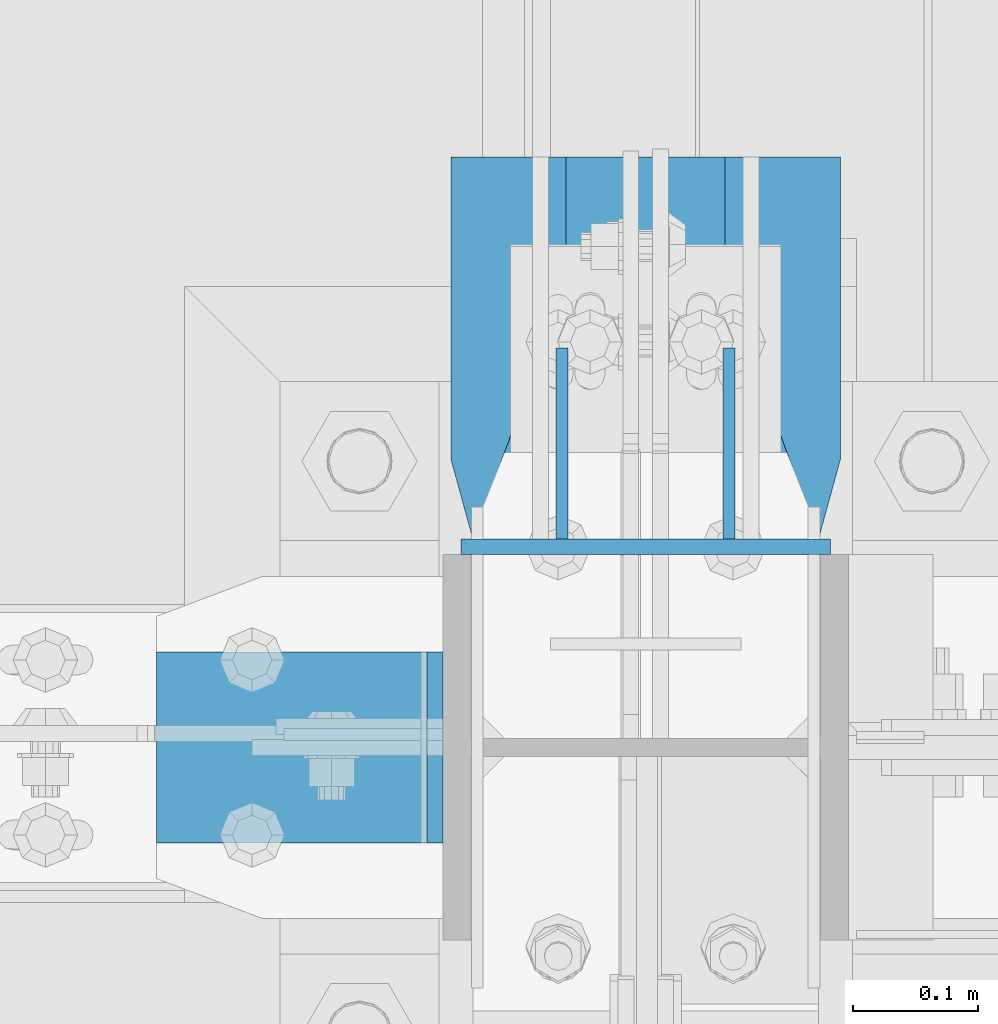
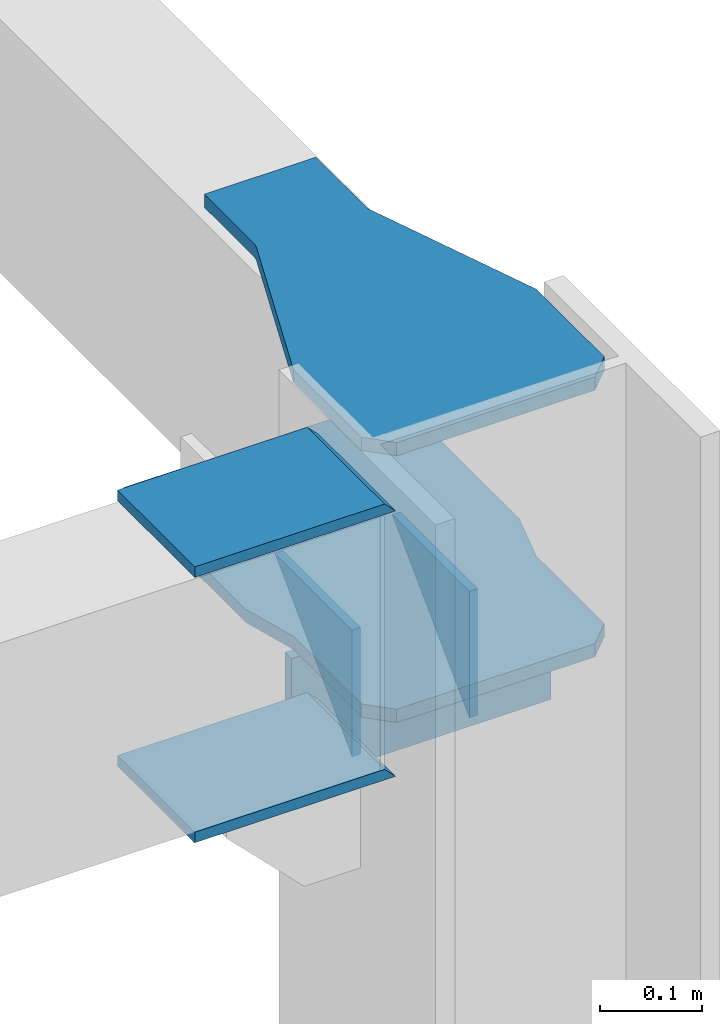
# One storey, part 896 of 1179: 7 beams, 2 elements without a shape of their own.
"""IFC2X3 building model written with IfcOpenShell, lengths in millimetres."""

from ifc_helpers import new_model, si_unit, frame, origin_with_axes, place, context, subcontext, project, spatial, faceted_brep, material, type_object, element, aggregate, save


model = new_model("IFC2X3")

# Units and contexts
model_context = context("Model", 3, precision=1e-05, world=origin_with_axes())
body_context = subcontext(model_context, "Body", "Model", "MODEL_VIEW")
ifc_project = project(units=[si_unit("LENGTHUNIT", "METRE", prefix="MILLI"), si_unit("AREAUNIT", "SQUARE_METRE"), si_unit("VOLUMEUNIT", "CUBIC_METRE"), si_unit("MASSUNIT", "GRAM", prefix="KILO"), si_unit("TIMEUNIT", "SECOND"), si_unit("PLANEANGLEUNIT", "RADIAN"), si_unit("SOLIDANGLEUNIT", "STERADIAN"), si_unit("THERMODYNAMICTEMPERATUREUNIT", "DEGREE_CELSIUS"), si_unit("LUMINOUSINTENSITYUNIT", "LUMEN")], contexts=[model_context])

# Site, building, storey
site_placement = place(None, origin_with_axes())
site = spatial("IfcSite", under=ifc_project, at=site_placement, CompositionType="ELEMENT")
building_placement = place(site_placement, origin_with_axes())
building = spatial("IfcBuilding", under=site, at=building_placement, Name="Undefined", CompositionType="ELEMENT")
storey_placement = place(building_placement, origin_with_axes())
storey = spatial("IfcBuildingStorey", under=building, at=storey_placement, Name="Undefined", CompositionType="ELEMENT", Elevation=0.0)

# Assembly, beams
assembly_1_placement = place(storey_placement, origin_with_axes())
assembly_1 = element("IfcElementAssembly", 1, at=assembly_1_placement, inside=storey, Name="COLUMN", AssemblyPlace="NOTDEFINED", PredefinedType="RIGID_FRAME")
ifc_material = material(Name="STEEL/A36")
beam_type_1 = type_object("IfcBeamType", PredefinedType="NOTDEFINED")
beam_1_placement = place(assembly_1_placement, frame((24455.4375, 34551.9375, 16030.575), z_axis=(0.0, 0.0, 1.0), x_axis=(-1.0, 0.0, 0.0)))
beam_1 = element("IfcBeam", 2, at=beam_1_placement, type_object=beam_type_1, material=ifc_material, Name="PLATE", context=body_context, shape_type="Brep", body=[
    faceted_brep([(-7.27595761418343e-12, 6.35000000000036, -76.1999999999971), (0.0, 6.35000000000036, 76.2000000000044), (295.274999999994, 6.34999999999854, 76.2000000000007), (295.274999999994, 6.34999999999854, -76.2000000000007), (0.0, -6.35000000000036, 76.2000000000044), (295.274999999994, -6.34999999999854, 76.2000000000007), (7.27595761418343e-12, -6.35000000000036, -76.1999999999971), (295.274999999994, -6.34999999999854, -76.2000000000007)], [[[0, 1, 2, 3]], [[1, 4, 5, 2]], [[4, 6, 7, 5]], [[6, 0, 3, 7]], [[5, 7, 3, 2]], [[6, 4, 1, 0]]]),
])
beam_2_placement = place(assembly_1_placement, frame((23917.2750001183, 34391.6, 16116.3), z_axis=(0.0, 1.0, 0.0), x_axis=(1.0, 0.0, 0.0)))
beam_2 = element("IfcBeam", 3, at=beam_2_placement, type_object=beam_type_1, material=ifc_material, Name="PLATE", context=body_context, shape_type="Brep", body=[
    faceted_brep([(215.899999999991, -6.35000000000036, -76.1999999999971), (228.599999999991, 6.35000000000036, -76.1999999999971), (228.599999999991, 6.35000000000036, 76.1999999999971), (215.899999999991, -6.35000000000036, 76.1999999999971), (-7.27595761418343e-12, 6.35000000000036, -76.1999999999971), (0.0, 6.35000000000036, 76.2000000000044), (0.0, -6.35000000000036, 76.2000000000044), (7.27595761418343e-12, -6.35000000000036, -76.1999999999971)], [[[0, 1, 2, 3]], [[4, 5, 2, 1]], [[5, 6, 3, 2]], [[6, 7, 0, 3]], [[7, 4, 1, 0]], [[7, 6, 5, 4]]]),
])
beam_3_placement = place(assembly_1_placement, frame((23917.275, 34391.6, 16435.3875), z_axis=(0.0, 1.0, 0.0), x_axis=(1.0, 0.0, 0.0)))
beam_3 = element("IfcBeam", 4, at=beam_3_placement, type_object=beam_type_1, material=ifc_material, Name="PLATE", context=body_context, shape_type="Brep", body=[
    faceted_brep([(215.899999999991, -6.35000000000036, -76.1999999999971), (228.599999999991, 6.35000000000036, -76.1999999999971), (228.599999999991, 6.35000000000036, 76.1999999999971), (215.899999999991, -6.35000000000036, 76.1999999999971), (-7.27595761418343e-12, 6.35000000000036, -76.1999999999971), (0.0, 6.35000000000036, 76.2000000000044), (0.0, -6.35000000000036, 76.2000000000044), (7.27595761418343e-12, -6.35000000000036, -76.1999999999971)], [[[0, 1, 2, 3]], [[4, 5, 2, 1]], [[5, 6, 3, 2]], [[6, 7, 0, 3]], [[7, 4, 1, 0]], [[7, 6, 5, 4]]]),
])
beam_type_2 = type_object("IfcBeamType", PredefinedType="NOTDEFINED")
beam_4_placement = place(assembly_1_placement, frame((24374.475, 34710.6875, 16030.575), z_axis=(0.0, 0.0, 1.0), x_axis=(0.0, -1.0, 0.0)))
beam_4 = element("IfcBeam", 5, at=beam_4_placement, type_object=beam_type_2, material=ifc_material, Name="PLATE", context=body_context, shape_type="Brep", body=[
    faceted_brep([(152.4, -4.76249999999709, 76.2), (152.4, -4.76249999999709, -76.2), (152.4, 4.76249999999709, -76.2), (152.4, 4.76249999999709, 76.2), (0.0, 4.76249999999982, 76.1999999999971), (0.0, -4.76249999999982, 76.1999999999971)], [[[0, 1, 2, 3]], [[3, 2, 4]], [[4, 5, 0, 3]], [[0, 5, 1]], [[4, 2, 1, 5]]]),
])
beam_5_placement = place(assembly_1_placement, frame((24241.125, 34710.6875, 16030.575), z_axis=(0.0, 0.0, 1.0), x_axis=(0.0, -1.0, 0.0)))
beam_5 = element("IfcBeam", 6, at=beam_5_placement, type_object=beam_type_2, material=ifc_material, Name="PLATE", context=body_context, shape_type="Brep", body=[
    faceted_brep([(152.4, -4.76249999999709, 76.2), (152.4, -4.76249999999709, -76.2), (152.4, 4.76249999999709, -76.2), (152.4, 4.76249999999709, 76.2), (0.0, 4.76249999999982, 76.1999999999971), (0.0, -4.76249999999982, 76.1999999999971)], [[[0, 1, 2, 3]], [[3, 2, 4]], [[4, 5, 0, 3]], [[0, 5, 1]], [[4, 2, 1, 5]]]),
])
beam_type_3 = type_object("IfcBeamType", PredefinedType="NOTDEFINED")
beam_6_placement = place(assembly_1_placement, frame((24307.8, 34863.0875, 16114.7125), z_axis=(-1.0, 0.0, 0.0), x_axis=(0.0, -1.0, 0.0)))
beam_6 = element("IfcBeam", 7, at=beam_6_placement, type_object=beam_type_3, material=ifc_material, Name="PLATE", context=body_context, shape_type="Brep", body=[
    faceted_brep([(464.343749647407, -7.9375, -112.71250000018), (438.943749647406, -7.9375, -138.112500006246), (438.943749647406, 7.9375, -138.112500006246), (464.343749647407, 7.9375, -112.71250000018), (464.343749647407, 7.9375, 112.712500762937), (438.943749647406, 7.9375, 138.112500762938), (438.943749647406, -7.9375, 138.112500762938), (464.343749647407, -7.9375, 112.712500762937), (241.300006103491, -7.9375, -155.575000000001), (241.300006103491, 7.9375, -155.575000000001), (304.79998778872, 7.9375, -138.112500038278), (304.79998778872, -7.9375, -138.112500038278), (0.0, -7.9375, -155.575000000001), (0.0, -7.9375, 155.575000000001), (0.0, 7.9375, 155.575000000001), (0.0, 7.9375, -155.575000000001), (241.300006103513, -7.9375, 155.575000000001), (241.300006103513, 7.9375, 155.575000000001), (304.799990844724, -7.9375, 138.112500762938), (304.799990844724, 7.9375, 138.112500762938)], [[[0, 1, 2, 3]], [[4, 5, 6, 7]], [[8, 9, 10, 11]], [[11, 10, 2, 1]], [[12, 13, 14, 15]], [[14, 13, 16, 17]], [[18, 19, 17, 16]], [[19, 18, 6, 5]], [[4, 7, 0, 3]], [[10, 9, 15, 14, 17, 19, 5, 4, 3, 2]], [[12, 15, 9, 8]], [[7, 6, 18, 16, 13, 12, 8, 11, 1, 0]]]),
])
aggregate(assembly_1, [beam_4, beam_5, beam_6, beam_1, beam_2, beam_3])

# Assembly, beam
assembly_2_placement = place(storey_placement, origin_with_axes())
assembly_2 = element("IfcElementAssembly", 8, at=assembly_2_placement, inside=storey, Name="PLATE", AssemblyPlace="NOTDEFINED", PredefinedType="RIGID_FRAME")
beam_type_4 = type_object("IfcBeamType", PredefinedType="NOTDEFINED")
beam_7_placement = place(assembly_2_placement, frame((24307.8, 34863.0875, 16435.3875), z_axis=(-1.0, 0.0, 0.0), x_axis=(0.0, -1.0, 0.0)))
beam_7 = element("IfcBeam", 9, at=beam_7_placement, type_object=beam_type_4, material=ifc_material, Name="PLATE", context=body_context, shape_type="Brep", body=[
    faceted_brep([(464.343749647407, -7.9375, -112.71250000018), (438.943749647406, -7.9375, -138.112500006246), (438.943749647406, 7.9375, -138.112500006246), (464.343749647407, 7.9375, -112.71250000018), (464.343749647407, 7.9375, 112.712500762937), (438.943749647406, 7.9375, 138.112500762938), (438.943749647406, -7.9375, 138.112500762938), (464.343749647407, -7.9375, 112.712500762937), (97.0841207160993, -7.9375, 63.4999984741225), (97.0841207160993, 7.9375, 63.4999984741225), (0.0, 7.9375, 63.5), (0.0, -7.9375, 63.5), (99.3158287045953, -7.9375, 63.5982301687436), (99.3158287045953, 7.9375, 63.5982301687436), (101.530274924517, -7.9375, 63.8921654521291), (101.530274924517, 7.9375, 63.8921654521291), (103.710331123249, -7.9375, 64.379530799768), (103.710331123249, 7.9375, 64.379530799768), (105.839135047427, -7.9375, 65.0565565482866), (105.839135047427, 7.9375, 65.0565565482866), (304.799990844724, -7.9375, 138.112500762938), (304.799990844724, 7.9375, 138.112500762938), (0.0, -7.9375, -63.5), (0.0, 7.9375, -63.5), (97.0841208027923, 7.9375, -63.5), (97.0841208027923, -7.9375, -63.5), (99.3158287494298, 7.9375, -63.5982316909285), (99.3158287494298, -7.9375, -63.5982316909285), (101.530274928467, 7.9375, -63.8921669632982), (101.530274928467, -7.9375, -63.8921669632982), (103.710331088252, 7.9375, -64.3795322927581), (103.710331088252, -7.9375, -64.3795322927581), (105.839134976348, 7.9375, -65.0565580162292), (105.839134976348, -7.9375, -65.0565580162292), (304.79998778872, -7.9375, -138.112500038278), (304.79998778872, 7.9375, -138.112500038278)], [[[0, 1, 2, 3]], [[4, 5, 6, 7]], [[8, 9, 10, 11]], [[12, 13, 9, 8]], [[14, 15, 13, 12]], [[16, 17, 15, 14]], [[18, 19, 17, 16]], [[20, 21, 19, 18]], [[22, 23, 24, 25]], [[25, 24, 26, 27]], [[27, 26, 28, 29]], [[29, 28, 30, 31]], [[31, 30, 32, 33]], [[34, 33, 32, 35]], [[34, 35, 2, 1]], [[4, 7, 0, 3]], [[7, 6, 20, 18, 16, 14, 12, 8, 11, 22, 25, 27, 29, 31, 33, 34, 1, 0]], [[22, 11, 10, 23]], [[35, 32, 30, 28, 26, 24, 23, 10, 9, 13, 15, 17, 19, 21, 5, 4, 3, 2]], [[21, 20, 6, 5]]]),
])
aggregate(assembly_2, [beam_7])

save(model, "model.ifc")
